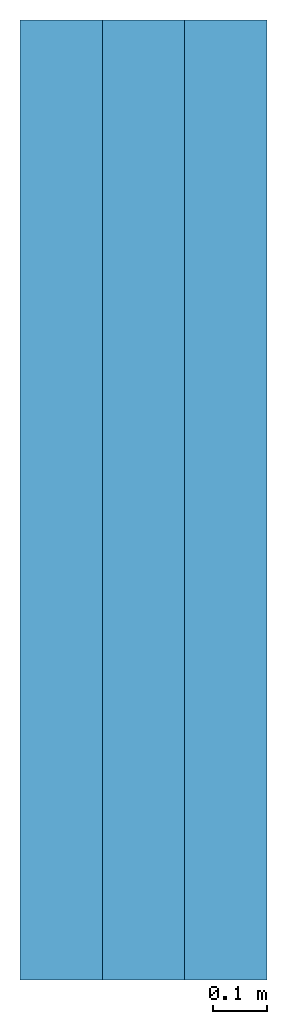
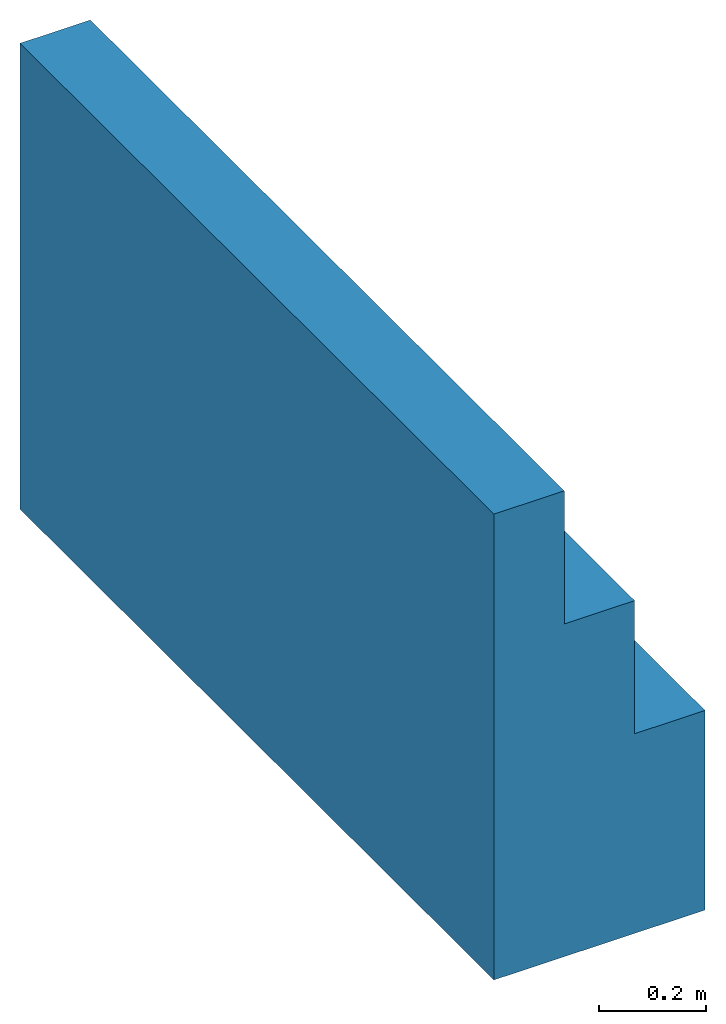
# One storey: 1 wall.
"""IFC2X3 building model written with IfcOpenShell, lengths in feet."""

from ifc_helpers import new_model, entity, si_unit, converted_unit, derived_unit, direction, frame, origin, place, context, subcontext, project, spatial, faceted_brep, material, type_object, element, save


model = new_model("IFC2X3")

# Units and contexts
model_context = context("Model", 3, precision=0.0001, world=origin(), true_north=direction((6.123031769111886e-17, 1.0)))
body_context = subcontext(model_context, "Body", "Model", "MODEL_VIEW")
ifc_project = project(units=[converted_unit("LENGTHUNIT", "FOOT", entity("IfcLengthMeasure", 0.3048), si_unit("LENGTHUNIT", "METRE"), dimensions=[1, 0, 0, 0, 0, 0, 0]), converted_unit("AREAUNIT", "SQUARE FOOT", entity("IfcAreaMeasure", 0.09290304), si_unit("AREAUNIT", "SQUARE_METRE"), dimensions=[2, 0, 0, 0, 0, 0, 0]), converted_unit("VOLUMEUNIT", "CUBIC FOOT", entity("IfcVolumeMeasure", 0.028316846592000004), si_unit("VOLUMEUNIT", "CUBIC_METRE"), dimensions=[3, 0, 0, 0, 0, 0, 0]), converted_unit("PLANEANGLEUNIT", "DEGREE", entity("IfcPlaneAngleMeasure", 0.017453292519943278), si_unit("PLANEANGLEUNIT", "RADIAN"), dimensions=[0, 0, 0, 0, 0, 0, 0]), si_unit("MASSUNIT", "GRAM", prefix="KILO"), derived_unit("MASSDENSITYUNIT", [(si_unit("MASSUNIT", "GRAM", prefix="KILO"), 1), (si_unit("LENGTHUNIT", "METRE"), -3)]), derived_unit("IONCONCENTRATIONUNIT", [(si_unit("MASSUNIT", "GRAM", prefix="KILO"), 1), (si_unit("LENGTHUNIT", "METRE"), -3)]), derived_unit("MOMENTOFINERTIAUNIT", [(si_unit("LENGTHUNIT", "METRE"), 4)]), si_unit("TIMEUNIT", "SECOND"), si_unit("FREQUENCYUNIT", "HERTZ"), si_unit("THERMODYNAMICTEMPERATUREUNIT", "DEGREE_CELSIUS"), derived_unit("THERMALTRANSMITTANCEUNIT", [(si_unit("MASSUNIT", "GRAM", prefix="KILO"), 1), (si_unit("THERMODYNAMICTEMPERATUREUNIT", "KELVIN"), -1), (si_unit("TIMEUNIT", "SECOND"), -3)]), derived_unit("THERMALCONDUCTANCEUNIT", [(si_unit("MASSUNIT", "GRAM", prefix="KILO"), 1), (si_unit("THERMODYNAMICTEMPERATUREUNIT", "KELVIN"), -1), (si_unit("TIMEUNIT", "SECOND"), -3), (si_unit("LENGTHUNIT", "METRE"), 1)]), derived_unit("VOLUMETRICFLOWRATEUNIT", [(si_unit("LENGTHUNIT", "METRE"), 3), (si_unit("TIMEUNIT", "SECOND"), -1)]), derived_unit("MASSFLOWRATEUNIT", [(si_unit("MASSUNIT", "GRAM", prefix="KILO"), 1), (si_unit("TIMEUNIT", "SECOND"), -1)]), derived_unit("ROTATIONALFREQUENCYUNIT", [(si_unit("TIMEUNIT", "SECOND"), -1)]), si_unit("ELECTRICCURRENTUNIT", "AMPERE"), si_unit("ELECTRICVOLTAGEUNIT", "VOLT"), si_unit("POWERUNIT", "WATT"), converted_unit("FORCEUNIT", "KIP", entity("IfcForceMeasure", 2.088543423315013e-05), si_unit("FORCEUNIT", "NEWTON"), dimensions=[1, 1, -2, 0, 0, 0, 0]), si_unit("ILLUMINANCEUNIT", "LUX"), si_unit("LUMINOUSFLUXUNIT", "LUMEN"), si_unit("LUMINOUSINTENSITYUNIT", "CANDELA"), si_unit("ENERGYUNIT", "JOULE"), derived_unit("USERDEFINED", [(si_unit("MASSUNIT", "GRAM", prefix="KILO"), -1), (si_unit("LENGTHUNIT", "METRE"), -2), (si_unit("TIMEUNIT", "SECOND"), 3), (si_unit("LUMINOUSFLUXUNIT", "LUMEN"), 1)]), derived_unit("USERDEFINED", [(si_unit("MASSUNIT", "GRAM", prefix="KILO"), 1), (si_unit("TIMEUNIT", "SECOND"), -3), (si_unit("LENGTHUNIT", "METRE"), 3), (si_unit("ELECTRICCURRENTUNIT", "AMPERE"), -2)]), derived_unit("SOUNDPOWERUNIT", [(si_unit("MASSUNIT", "GRAM", prefix="KILO"), 1), (si_unit("TIMEUNIT", "SECOND"), -3), (si_unit("LENGTHUNIT", "METRE"), 2)]), derived_unit("SOUNDPRESSUREUNIT", [(si_unit("MASSUNIT", "GRAM", prefix="KILO"), 1), (si_unit("LENGTHUNIT", "METRE"), -1), (si_unit("TIMEUNIT", "SECOND"), -2)]), derived_unit("LINEARVELOCITYUNIT", [(si_unit("LENGTHUNIT", "METRE"), 1), (si_unit("TIMEUNIT", "SECOND"), -1)]), si_unit("PRESSUREUNIT", "PASCAL"), derived_unit("USERDEFINED", [(si_unit("MASSUNIT", "GRAM", prefix="KILO"), 1), (si_unit("LENGTHUNIT", "METRE"), -2), (si_unit("TIMEUNIT", "SECOND"), -2)]), derived_unit("LINEARFORCEUNIT", [(si_unit("MASSUNIT", "GRAM", prefix="KILO"), 1), (si_unit("TIMEUNIT", "SECOND"), -2)]), derived_unit("PLANARFORCEUNIT", [(si_unit("MASSUNIT", "GRAM", prefix="KILO"), 1), (si_unit("LENGTHUNIT", "METRE"), -1), (si_unit("TIMEUNIT", "SECOND"), -2)]), derived_unit("SPECIFICHEATCAPACITYUNIT", [(si_unit("THERMODYNAMICTEMPERATUREUNIT", "KELVIN"), -1), (si_unit("LENGTHUNIT", "METRE"), 2), (si_unit("TIMEUNIT", "SECOND"), -2)]), derived_unit("HEATFLUXDENSITYUNIT", [(si_unit("MASSUNIT", "GRAM", prefix="KILO"), 1), (si_unit("TIMEUNIT", "SECOND"), -3)]), derived_unit("HEATINGVALUEUNIT", [(si_unit("LENGTHUNIT", "METRE"), 2), (si_unit("TIMEUNIT", "SECOND"), -2)]), derived_unit("VAPORPERMEABILITYUNIT", [(si_unit("LENGTHUNIT", "METRE"), -1), (si_unit("TIMEUNIT", "SECOND"), 1)]), derived_unit("DYNAMICVISCOSITYUNIT", [(si_unit("MASSUNIT", "GRAM", prefix="KILO"), 1), (si_unit("TIMEUNIT", "SECOND"), -1), (si_unit("LENGTHUNIT", "METRE"), -1)]), derived_unit("THERMALEXPANSIONCOEFFICIENTUNIT", [(si_unit("THERMODYNAMICTEMPERATUREUNIT", "KELVIN"), -1)]), derived_unit("MODULUSOFELASTICITYUNIT", [(si_unit("MASSUNIT", "GRAM", prefix="KILO"), 1), (si_unit("LENGTHUNIT", "METRE"), -1), (si_unit("TIMEUNIT", "SECOND"), -2)]), derived_unit("ISOTHERMALMOISTURECAPACITYUNIT", [(si_unit("LENGTHUNIT", "METRE"), 3), (si_unit("MASSUNIT", "GRAM", prefix="KILO"), -1)]), derived_unit("MOISTUREDIFFUSIVITYUNIT", [(si_unit("TIMEUNIT", "SECOND"), -1), (si_unit("LENGTHUNIT", "METRE"), 2)]), derived_unit("MASSPERLENGTHUNIT", [(si_unit("MASSUNIT", "GRAM", prefix="KILO"), 1), (si_unit("LENGTHUNIT", "METRE"), -1)]), derived_unit("THERMALRESISTANCEUNIT", [(si_unit("MASSUNIT", "GRAM", prefix="KILO"), -1), (si_unit("TIMEUNIT", "SECOND"), 3), (si_unit("THERMODYNAMICTEMPERATUREUNIT", "KELVIN"), 1)]), derived_unit("ACCELERATIONUNIT", [(si_unit("LENGTHUNIT", "METRE"), 1), (si_unit("TIMEUNIT", "SECOND"), -2)]), derived_unit("ANGULARVELOCITYUNIT", [(si_unit("TIMEUNIT", "SECOND"), -1), (si_unit("PLANEANGLEUNIT", "RADIAN"), 1)]), derived_unit("LINEARSTIFFNESSUNIT", [(si_unit("MASSUNIT", "GRAM", prefix="KILO"), 1), (si_unit("TIMEUNIT", "SECOND"), -2)]), derived_unit("WARPINGCONSTANTUNIT", [(si_unit("LENGTHUNIT", "METRE"), 6)]), derived_unit("LINEARMOMENTUNIT", [(si_unit("MASSUNIT", "GRAM", prefix="KILO"), 1), (si_unit("LENGTHUNIT", "METRE"), 1), (si_unit("TIMEUNIT", "SECOND"), -2)]), derived_unit("TORQUEUNIT", [(si_unit("MASSUNIT", "GRAM", prefix="KILO"), 1), (si_unit("LENGTHUNIT", "METRE"), 2), (si_unit("TIMEUNIT", "SECOND"), -2)])], contexts=[model_context])

# Site, building, storey
site_placement = place(None, origin())
site = spatial("IfcSite", under=ifc_project, at=site_placement, CompositionType="ELEMENT")
building_placement = place(site_placement, origin())
building = spatial("IfcBuilding", under=site, at=building_placement, CompositionType="ELEMENT")
storey_placement = place(building_placement, frame((0.0, 0.0, -2.0)))
storey = spatial("IfcBuildingStorey", under=building, at=storey_placement, CompositionType="ELEMENT", Elevation=-2.0)

# Wall
ifc_material = material(Name="Default Wall")
wall_type = type_object("IfcWallType", Name="Walls 12:Walls 12", PredefinedType="NOTDEFINED", material=ifc_material)
wall_placement = place(storey_placement, frame((48.37447801916217, -40.17457818058239, -1.4697158957165906), z_axis=(0.0, 0.0, 1.0), x_axis=(0.0, 1.0, 0.0)))
element("IfcWall", 1, at=wall_placement, inside=storey, type_object=wall_type, material=ifc_material, Name="Walls 12:Walls 12", ObjectType="Walls 12:Walls 12", context=body_context, shape_type="Brep", body=[
    faceted_brep([(0.0, -1.5, 0.0), (0.0, -1.5, 1.5000000000000187), (0.0, -1.0, 1.5000000000000187), (0.0, -1.0, 2.5000000000000187), (0.0, -0.5, 2.5000000000000187), (0.0, -0.5, 3.5000000000000187), (0.0, 0.0, 3.5000000000000178), (0.0, 0.0, 0.0), (5.8333333333334, -1.5, 0.0), (5.8333333333334, 0.0, 0.0), (5.833333333333414, 0.0, 3.499999999999999), (5.833333333333414, -0.5, 3.5), (5.833333333333407, -0.5, 2.5), (5.833333333333407, -1.0, 2.5), (5.833333333333407, -1.0, 1.4999999999999998), (5.833333333333407, -1.5, 1.5)], [[[0, 1, 2, 3, 4, 5, 6, 7]], [[8, 9, 10, 11, 12, 13, 14, 15]], [[1, 0, 8, 15]], [[2, 1, 15, 14]], [[3, 2, 14, 13]], [[4, 3, 13, 12]], [[5, 4, 12, 11]], [[6, 5, 11, 10]], [[7, 6, 10, 9]], [[0, 7, 9, 8]]]),
])

save(model, "model.ifc")
